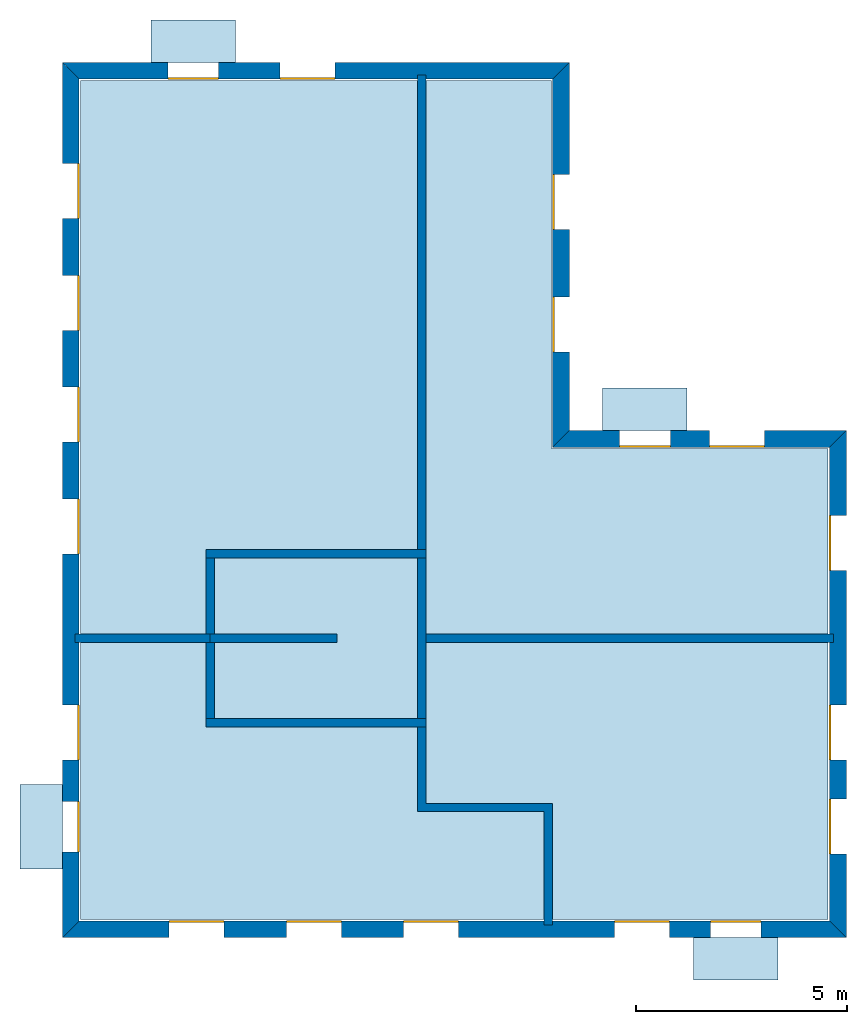
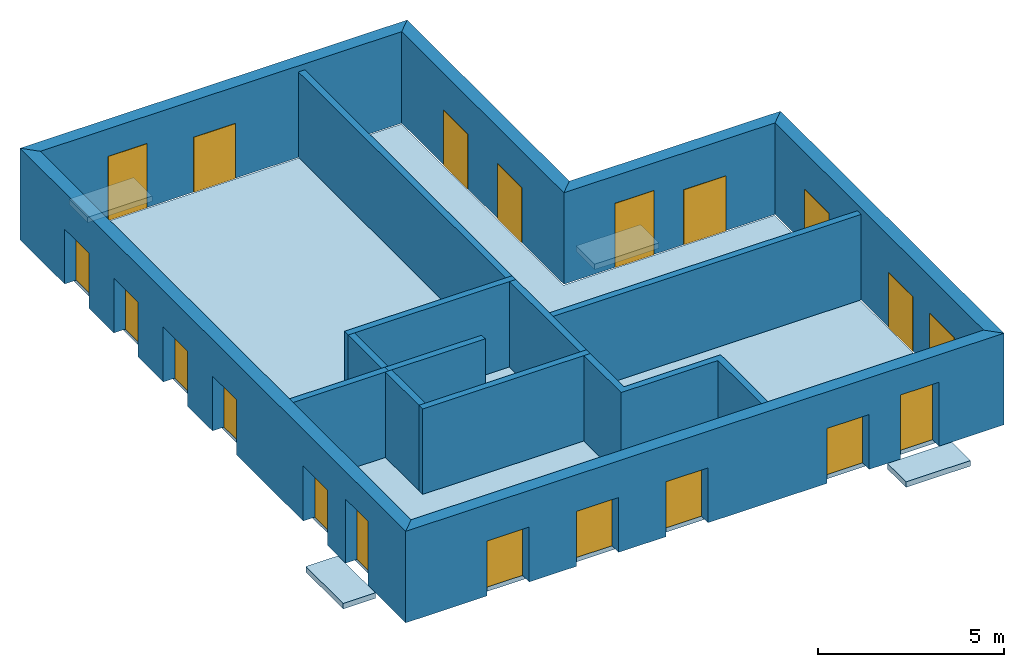
# One storey: 20 windows, 15 walls, 5 slabs, 20 openings.
"""IFC4 building model written with IfcOpenShell, lengths in metres."""

from ifc_helpers import new_model, si_unit, frame, origin_with_axes, place, context, subcontext, project, spatial, line, indexed_curve, outline, extrude, element, fill, save


model = new_model("IFC4")

# Units and contexts
model_context = context("Model", 3, precision=1e-05, world=origin_with_axes())
body_context = subcontext(model_context, "Body", "Model", "MODEL_VIEW")
ifc_project = project(units=[si_unit("VOLUMEUNIT", "CUBIC_METRE"), si_unit("LENGTHUNIT", "METRE"), si_unit("AREAUNIT", "SQUARE_METRE")], contexts=[model_context])

# Site, building, storey
site = spatial("IfcSite", under=ifc_project)
building = spatial("IfcBuilding", under=site, Name="Building 2")
storey_placement = place(None, frame((0.0, 0.0, 4.0), z_axis=(0.0, 0.0, 1.0), x_axis=(1.0, 0.0, 0.0)))
storey = spatial("IfcBuildingStorey", under=building, at=storey_placement, Name="02 Storey")

# Slabs
slab_1_placement = place(storey_placement, origin_with_axes())
element("IfcSlab", 1, at=slab_1_placement, inside=storey, Name="Slab", context=body_context, shape_type="SweptSolid", body=[
    extrude(outline(indexed_curve([(22.109464, -3.589175), (15.563354, -3.589175), (15.563354, 5.1182), (4.423354, 5.1182), (4.423354, -14.729175), (22.109464, -14.729175)], segments=[line(1, 2), line(2, 3), line(3, 4), line(4, 5), line(5, 6)])), origin_with_axes(), (0.0, 0.0, -1.0), 0.2),
])
slab_2_placement = place(storey_placement, origin_with_axes())
element("IfcSlab", 2, at=slab_2_placement, inside=storey, Name="Balcony", context=body_context, shape_type="SweptSolid", body=[
    extrude(outline(indexed_curve([(6.093354, 5.5482), (6.093354, 6.5482), (8.093354, 6.5482), (8.093354, 5.5482)], segments=[line(1, 2), line(2, 3), line(3, 4)])), origin_with_axes(), (0.0, 0.0, -1.0), 0.18),
])
slab_3_placement = place(storey_placement, origin_with_axes())
element("IfcSlab", 3, at=slab_3_placement, inside=storey, Name="Balcony", context=body_context, shape_type="SweptSolid", body=[
    extrude(outline(indexed_curve([(16.7753906666667, -3.159175), (16.7753906666667, -2.159175), (18.7753906666667, -2.159175), (18.7753906666667, -3.159175)], segments=[line(1, 2), line(2, 3), line(3, 4)])), origin_with_axes(), (0.0, 0.0, -1.0), 0.18),
])
slab_4_placement = place(storey_placement, origin_with_axes())
element("IfcSlab", 4, at=slab_4_placement, inside=storey, Name="Balcony", context=body_context, shape_type="SweptSolid", body=[
    extrude(outline(indexed_curve([(20.924094, -15.159175), (20.924094, -16.159175), (18.924094, -16.159175), (18.924094, -15.159175)], segments=[line(1, 2), line(2, 3), line(3, 4)])), origin_with_axes(), (0.0, 0.0, -1.0), 0.18),
])
slab_5_placement = place(storey_placement, origin_with_axes())
element("IfcSlab", 5, at=slab_5_placement, inside=storey, Name="Balcony", context=body_context, shape_type="SweptSolid", body=[
    extrude(outline(indexed_curve([(3.993354, -13.5322976666667), (2.993354, -13.5322976666667), (2.993354, -11.5322976666667), (3.993354, -11.5322976666667)], segments=[line(1, 2), line(2, 3), line(3, 4)])), origin_with_axes(), (0.0, 0.0, -1.0), 0.18),
])

# Walls
wall_1_placement = place(storey_placement, origin_with_axes())
element("IfcWall", 6, at=wall_1_placement, inside=storey, Name="Wall", context=body_context, shape_type="SweptSolid", body=[
    extrude(outline(indexed_curve([(7.593354, -7.978543), (4.293354, -7.978543), (4.293354, -8.178543), (7.593354, -8.178543)], segments=[line(1, 2), line(2, 3), line(3, 4)])), origin_with_axes(), (0.0, 0.0, 1.0), 2.8),
])
wall_2_placement = place(storey_placement, origin_with_axes())
element("IfcWall", 7, at=wall_2_placement, inside=storey, Name="Wall", context=body_context, shape_type="SweptSolid", body=[
    extrude(outline(indexed_curve([(12.593354, 5.2482), (12.393354, 5.2482), (12.393354, -6.178543), (12.593354, -6.178543)], segments=[line(1, 2), line(2, 3), line(3, 4)])), origin_with_axes(), (0.0, 0.0, 1.0), 2.8),
])
wall_3_placement = place(storey_placement, origin_with_axes())
element("IfcWall", 8, at=wall_3_placement, inside=storey, Name="Wall", context=body_context, shape_type="SweptSolid", body=[
    extrude(outline(indexed_curve([(22.239464, -7.978543), (12.393354, -7.978543), (12.393354, -8.178543), (22.239464, -8.178543)], segments=[line(1, 2), line(2, 3), line(3, 4)])), origin_with_axes(), (0.0, 0.0, 1.0), 2.8),
])
wall_4_placement = place(storey_placement, origin_with_axes())
element("IfcWall", 9, at=wall_4_placement, inside=storey, Name="Wall", context=body_context, shape_type="SweptSolid", body=[
    extrude(outline(indexed_curve([(15.593354, -11.978543), (12.593354, -11.978543), (12.593354, -9.978543), (12.393354, -9.978543), (12.393354, -12.178543), (15.393354, -12.178543), (15.393354, -14.859175), (15.593354, -14.859175)], segments=[line(1, 2), line(2, 3), line(3, 4), line(4, 5), line(5, 6), line(6, 7), line(7, 8)])), origin_with_axes(), (0.0, 0.0, 1.0), 2.8),
])

# Wall, openings, windows
wall_5_placement = place(storey_placement, origin_with_axes())
wall_5 = element("IfcWall", 10, at=wall_5_placement, inside=storey, Name="Facade", context=body_context, shape_type="SweptSolid", body=[
    extrude(outline(indexed_curve([(22.139464, -3.559175), (15.593354, -3.559175), (15.993354, -3.159175), (22.539464, -3.159175)], segments=[line(1, 2), line(2, 3), line(3, 4)])), origin_with_axes(), (0.0, 0.0, 1.0), 3.0),
])
opening_1_placement = place(wall_5_placement, origin_with_axes())
opening_1 = element("IfcOpeningElement", 11, at=opening_1_placement, cuts=wall_5, Name="Opening", context=body_context, shape_type="SweptSolid", body=[
    extrude(outline(indexed_curve([(20.6074273333333, -3.119175), (20.6074273333333, -3.619175), (19.3074273333333, -3.619175), (19.3074273333333, -3.119175)], segments=[line(1, 2), line(2, 3), line(3, 4)])), origin_with_axes(), (0.0, 0.0, 1.0), 1.8),
])
opening_2_placement = place(wall_5_placement, origin_with_axes())
opening_2 = element("IfcOpeningElement", 12, at=opening_2_placement, cuts=wall_5, Name="Opening", context=body_context, shape_type="SweptSolid", body=[
    extrude(outline(indexed_curve([(18.3753906666667, -3.119175), (18.3753906666667, -3.619175), (17.1753906666667, -3.619175), (17.1753906666667, -3.119175)], segments=[line(1, 2), line(2, 3), line(3, 4)])), origin_with_axes(), (0.0, 0.0, 1.0), 2.1),
])
window_1_placement = place(storey_placement, origin_with_axes())
window_1 = element("IfcWindow", 13, at=window_1_placement, inside=storey, Name="Window", PredefinedType="WINDOW", context=body_context, shape_type="SweptSolid", body=[
    extrude(outline(indexed_curve([(20.6074273333333, -3.519175), (20.6074273333333, -3.569175), (19.3074273333333, -3.569175), (19.3074273333333, -3.519175)], segments=[line(1, 2), line(2, 3), line(3, 4)])), origin_with_axes(), (0.0, 0.0, 1.0), 1.8),
])
fill(opening_1, window_1)
window_2_placement = place(storey_placement, origin_with_axes())
window_2 = element("IfcWindow", 14, at=window_2_placement, inside=storey, Name="Window", PredefinedType="WINDOW", context=body_context, shape_type="SweptSolid", body=[
    extrude(outline(indexed_curve([(18.3753906666667, -3.519175), (18.3753906666667, -3.569175), (17.1753906666667, -3.569175), (17.1753906666667, -3.519175)], segments=[line(1, 2), line(2, 3), line(3, 4)])), origin_with_axes(), (0.0, 0.0, 1.0), 2.1),
])
fill(opening_2, window_2)

wall_6_placement = place(storey_placement, origin_with_axes())
wall_6 = element("IfcWall", 15, at=wall_6_placement, inside=storey, Name="Facade", context=body_context, shape_type="SweptSolid", body=[
    extrude(outline(indexed_curve([(15.593354, -3.559175), (15.593354, 5.1482), (15.993354, 5.5482), (15.993354, -3.159175)], segments=[line(1, 2), line(2, 3), line(3, 4)])), origin_with_axes(), (0.0, 0.0, 1.0), 3.0),
])
opening_3_placement = place(wall_6_placement, origin_with_axes())
opening_3 = element("IfcOpeningElement", 16, at=opening_3_placement, cuts=wall_6, Name="Opening", context=body_context, shape_type="SweptSolid", body=[
    extrude(outline(indexed_curve([(16.033354, -1.30671666666667), (15.533354, -1.30671666666667), (15.533354, -0.00671666666666659), (16.033354, -0.00671666666666659)], segments=[line(1, 2), line(2, 3), line(3, 4)])), origin_with_axes(), (0.0, 0.0, 1.0), 1.8),
])
opening_4_placement = place(wall_6_placement, origin_with_axes())
opening_4 = element("IfcOpeningElement", 17, at=opening_4_placement, cuts=wall_6, Name="Opening", context=body_context, shape_type="SweptSolid", body=[
    extrude(outline(indexed_curve([(16.033354, 1.59574166666667), (15.533354, 1.59574166666667), (15.533354, 2.89574166666667), (16.033354, 2.89574166666667)], segments=[line(1, 2), line(2, 3), line(3, 4)])), origin_with_axes(), (0.0, 0.0, 1.0), 1.8),
])
window_3_placement = place(storey_placement, origin_with_axes())
window_3 = element("IfcWindow", 18, at=window_3_placement, inside=storey, Name="Window", PredefinedType="WINDOW", context=body_context, shape_type="SweptSolid", body=[
    extrude(outline(indexed_curve([(15.633354, -1.30671666666667), (15.583354, -1.30671666666667), (15.583354, -0.00671666666666659), (15.633354, -0.00671666666666659)], segments=[line(1, 2), line(2, 3), line(3, 4)])), origin_with_axes(), (0.0, 0.0, 1.0), 1.8),
])
fill(opening_3, window_3)
window_4_placement = place(storey_placement, origin_with_axes())
window_4 = element("IfcWindow", 19, at=window_4_placement, inside=storey, Name="Window", PredefinedType="WINDOW", context=body_context, shape_type="SweptSolid", body=[
    extrude(outline(indexed_curve([(15.633354, 1.59574166666667), (15.583354, 1.59574166666667), (15.583354, 2.89574166666667), (15.633354, 2.89574166666667)], segments=[line(1, 2), line(2, 3), line(3, 4)])), origin_with_axes(), (0.0, 0.0, 1.0), 1.8),
])
fill(opening_4, window_4)

wall_7_placement = place(storey_placement, origin_with_axes())
wall_7 = element("IfcWall", 20, at=wall_7_placement, inside=storey, Name="Facade", context=body_context, shape_type="SweptSolid", body=[
    extrude(outline(indexed_curve([(15.593354, 5.1482), (4.393354, 5.1482), (3.993354, 5.5482), (15.993354, 5.5482)], segments=[line(1, 2), line(2, 3), line(3, 4)])), origin_with_axes(), (0.0, 0.0, 1.0), 3.0),
])
opening_5_placement = place(wall_7_placement, origin_with_axes())
opening_5 = element("IfcOpeningElement", 21, at=opening_5_placement, cuts=wall_7, Name="Opening", context=body_context, shape_type="SweptSolid", body=[
    extrude(outline(indexed_curve([(10.443354, 5.5882), (10.443354, 5.0882), (9.143354, 5.0882), (9.143354, 5.5882)], segments=[line(1, 2), line(2, 3), line(3, 4)])), origin_with_axes(), (0.0, 0.0, 1.0), 1.8),
])
opening_6_placement = place(wall_7_placement, origin_with_axes())
opening_6 = element("IfcOpeningElement", 22, at=opening_6_placement, cuts=wall_7, Name="Opening", context=body_context, shape_type="SweptSolid", body=[
    extrude(outline(indexed_curve([(7.693354, 5.5882), (7.693354, 5.0882), (6.493354, 5.0882), (6.493354, 5.5882)], segments=[line(1, 2), line(2, 3), line(3, 4)])), origin_with_axes(), (0.0, 0.0, 1.0), 2.1),
])
window_5_placement = place(storey_placement, origin_with_axes())
window_5 = element("IfcWindow", 23, at=window_5_placement, inside=storey, Name="Window", PredefinedType="WINDOW", context=body_context, shape_type="SweptSolid", body=[
    extrude(outline(indexed_curve([(10.443354, 5.1882), (10.443354, 5.1382), (9.143354, 5.1382), (9.143354, 5.1882)], segments=[line(1, 2), line(2, 3), line(3, 4)])), origin_with_axes(), (0.0, 0.0, 1.0), 1.8),
])
fill(opening_5, window_5)
window_6_placement = place(storey_placement, origin_with_axes())
window_6 = element("IfcWindow", 24, at=window_6_placement, inside=storey, Name="Window", PredefinedType="WINDOW", context=body_context, shape_type="SweptSolid", body=[
    extrude(outline(indexed_curve([(7.693354, 5.1882), (7.693354, 5.1382), (6.493354, 5.1382), (6.493354, 5.1882)], segments=[line(1, 2), line(2, 3), line(3, 4)])), origin_with_axes(), (0.0, 0.0, 1.0), 2.1),
])
fill(opening_6, window_6)

wall_8_placement = place(storey_placement, origin_with_axes())
wall_8 = element("IfcWall", 25, at=wall_8_placement, inside=storey, Name="Facade", context=body_context, shape_type="SweptSolid", body=[
    extrude(outline(indexed_curve([(4.393354, 5.1482), (4.393354, -14.759175), (3.993354, -15.159175), (3.993354, 5.5482)], segments=[line(1, 2), line(2, 3), line(3, 4)])), origin_with_axes(), (0.0, 0.0, 1.0), 3.0),
])
opening_7_placement = place(wall_8_placement, origin_with_axes())
opening_7 = element("IfcOpeningElement", 26, at=opening_7_placement, cuts=wall_8, Name="Opening", context=body_context, shape_type="SweptSolid", body=[
    extrude(outline(indexed_curve([(3.953354, 3.1528514), (4.453354, 3.1528514), (4.453354, 1.8528514), (3.953354, 1.8528514)], segments=[line(1, 2), line(2, 3), line(3, 4)])), origin_with_axes(), (0.0, 0.0, 1.0), 1.8),
])
opening_8_placement = place(wall_8_placement, origin_with_axes())
opening_8 = element("IfcOpeningElement", 27, at=opening_8_placement, cuts=wall_8, Name="Opening", context=body_context, shape_type="SweptSolid", body=[
    extrude(outline(indexed_curve([(3.953354, 0.507502800000001), (4.453354, 0.507502800000001), (4.453354, -0.792497199999999), (3.953354, -0.792497199999999)], segments=[line(1, 2), line(2, 3), line(3, 4)])), origin_with_axes(), (0.0, 0.0, 1.0), 1.8),
])
opening_9_placement = place(wall_8_placement, origin_with_axes())
opening_9 = element("IfcOpeningElement", 28, at=opening_9_placement, cuts=wall_8, Name="Opening", context=body_context, shape_type="SweptSolid", body=[
    extrude(outline(indexed_curve([(3.953354, -2.1378458), (4.453354, -2.1378458), (4.453354, -3.4378458), (3.953354, -3.4378458)], segments=[line(1, 2), line(2, 3), line(3, 4)])), origin_with_axes(), (0.0, 0.0, 1.0), 1.8),
])
opening_10_placement = place(wall_8_placement, origin_with_axes())
opening_10 = element("IfcOpeningElement", 29, at=opening_10_placement, cuts=wall_8, Name="Opening", context=body_context, shape_type="SweptSolid", body=[
    extrude(outline(indexed_curve([(3.953354, -4.7831944), (4.453354, -4.7831944), (4.453354, -6.0831944), (3.953354, -6.0831944)], segments=[line(1, 2), line(2, 3), line(3, 4)])), origin_with_axes(), (0.0, 0.0, 1.0), 1.8),
])
opening_11_placement = place(wall_8_placement, origin_with_axes())
opening_11 = element("IfcOpeningElement", 30, at=opening_11_placement, cuts=wall_8, Name="Opening", context=body_context, shape_type="SweptSolid", body=[
    extrude(outline(indexed_curve([(3.953354, -9.65542033333333), (4.453354, -9.65542033333333), (4.453354, -10.9554203333333), (3.953354, -10.9554203333333)], segments=[line(1, 2), line(2, 3), line(3, 4)])), origin_with_axes(), (0.0, 0.0, 1.0), 1.8),
])
opening_12_placement = place(wall_8_placement, origin_with_axes())
opening_12 = element("IfcOpeningElement", 31, at=opening_12_placement, cuts=wall_8, Name="Opening", context=body_context, shape_type="SweptSolid", body=[
    extrude(outline(indexed_curve([(3.953354, -11.9322976666667), (4.453354, -11.9322976666667), (4.453354, -13.1322976666667), (3.953354, -13.1322976666667)], segments=[line(1, 2), line(2, 3), line(3, 4)])), origin_with_axes(), (0.0, 0.0, 1.0), 2.1),
])
window_7_placement = place(storey_placement, origin_with_axes())
window_7 = element("IfcWindow", 32, at=window_7_placement, inside=storey, Name="Window", PredefinedType="WINDOW", context=body_context, shape_type="SweptSolid", body=[
    extrude(outline(indexed_curve([(4.353354, 3.1528514), (4.403354, 3.1528514), (4.403354, 1.8528514), (4.353354, 1.8528514)], segments=[line(1, 2), line(2, 3), line(3, 4)])), origin_with_axes(), (0.0, 0.0, 1.0), 1.8),
])
fill(opening_7, window_7)
window_8_placement = place(storey_placement, origin_with_axes())
window_8 = element("IfcWindow", 33, at=window_8_placement, inside=storey, Name="Window", PredefinedType="WINDOW", context=body_context, shape_type="SweptSolid", body=[
    extrude(outline(indexed_curve([(4.353354, 0.507502800000001), (4.403354, 0.507502800000001), (4.403354, -0.792497199999999), (4.353354, -0.792497199999999)], segments=[line(1, 2), line(2, 3), line(3, 4)])), origin_with_axes(), (0.0, 0.0, 1.0), 1.8),
])
fill(opening_8, window_8)
window_9_placement = place(storey_placement, origin_with_axes())
window_9 = element("IfcWindow", 34, at=window_9_placement, inside=storey, Name="Window", PredefinedType="WINDOW", context=body_context, shape_type="SweptSolid", body=[
    extrude(outline(indexed_curve([(4.353354, -2.1378458), (4.403354, -2.1378458), (4.403354, -3.4378458), (4.353354, -3.4378458)], segments=[line(1, 2), line(2, 3), line(3, 4)])), origin_with_axes(), (0.0, 0.0, 1.0), 1.8),
])
fill(opening_9, window_9)
window_10_placement = place(storey_placement, origin_with_axes())
window_10 = element("IfcWindow", 35, at=window_10_placement, inside=storey, Name="Window", PredefinedType="WINDOW", context=body_context, shape_type="SweptSolid", body=[
    extrude(outline(indexed_curve([(4.353354, -4.7831944), (4.403354, -4.7831944), (4.403354, -6.0831944), (4.353354, -6.0831944)], segments=[line(1, 2), line(2, 3), line(3, 4)])), origin_with_axes(), (0.0, 0.0, 1.0), 1.8),
])
fill(opening_10, window_10)
window_11_placement = place(storey_placement, origin_with_axes())
window_11 = element("IfcWindow", 36, at=window_11_placement, inside=storey, Name="Window", PredefinedType="WINDOW", context=body_context, shape_type="SweptSolid", body=[
    extrude(outline(indexed_curve([(4.353354, -9.65542033333333), (4.403354, -9.65542033333333), (4.403354, -10.9554203333333), (4.353354, -10.9554203333333)], segments=[line(1, 2), line(2, 3), line(3, 4)])), origin_with_axes(), (0.0, 0.0, 1.0), 1.8),
])
fill(opening_11, window_11)
window_12_placement = place(storey_placement, origin_with_axes())
window_12 = element("IfcWindow", 37, at=window_12_placement, inside=storey, Name="Window", PredefinedType="WINDOW", context=body_context, shape_type="SweptSolid", body=[
    extrude(outline(indexed_curve([(4.353354, -11.9322976666667), (4.403354, -11.9322976666667), (4.403354, -13.1322976666667), (4.353354, -13.1322976666667)], segments=[line(1, 2), line(2, 3), line(3, 4)])), origin_with_axes(), (0.0, 0.0, 1.0), 2.1),
])
fill(opening_12, window_12)

wall_9_placement = place(storey_placement, origin_with_axes())
wall_9 = element("IfcWall", 38, at=wall_9_placement, inside=storey, Name="Facade", context=body_context, shape_type="SweptSolid", body=[
    extrude(outline(indexed_curve([(4.393354, -14.759175), (22.139464, -14.759175), (22.539464, -15.159175), (3.993354, -15.159175)], segments=[line(1, 2), line(2, 3), line(3, 4)])), origin_with_axes(), (0.0, 0.0, 1.0), 3.0),
])
opening_13_placement = place(wall_9_placement, origin_with_axes())
opening_13 = element("IfcOpeningElement", 39, at=opening_13_placement, cuts=wall_9, Name="Opening", context=body_context, shape_type="SweptSolid", body=[
    extrude(outline(indexed_curve([(17.058724, -15.199175), (17.058724, -14.699175), (18.358724, -14.699175), (18.358724, -15.199175)], segments=[line(1, 2), line(2, 3), line(3, 4)])), origin_with_axes(), (0.0, 0.0, 1.0), 1.8),
])
opening_14_placement = place(wall_9_placement, origin_with_axes())
opening_14 = element("IfcOpeningElement", 40, at=opening_14_placement, cuts=wall_9, Name="Opening", context=body_context, shape_type="SweptSolid", body=[
    extrude(outline(indexed_curve([(19.324094, -15.199175), (19.324094, -14.699175), (20.524094, -14.699175), (20.524094, -15.199175)], segments=[line(1, 2), line(2, 3), line(3, 4)])), origin_with_axes(), (0.0, 0.0, 1.0), 2.1),
])
opening_15_placement = place(wall_9_placement, origin_with_axes())
opening_15 = element("IfcOpeningElement", 41, at=opening_15_placement, cuts=wall_9, Name="Opening", context=body_context, shape_type="SweptSolid", body=[
    extrude(outline(indexed_curve([(6.518354, -15.199175), (6.518354, -14.699175), (7.818354, -14.699175), (7.818354, -15.199175)], segments=[line(1, 2), line(2, 3), line(3, 4)])), origin_with_axes(), (0.0, 0.0, 1.0), 1.8),
])
opening_16_placement = place(wall_9_placement, origin_with_axes())
opening_16 = element("IfcOpeningElement", 42, at=opening_16_placement, cuts=wall_9, Name="Opening", context=body_context, shape_type="SweptSolid", body=[
    extrude(outline(indexed_curve([(9.293354, -15.199175), (9.293354, -14.699175), (10.593354, -14.699175), (10.593354, -15.199175)], segments=[line(1, 2), line(2, 3), line(3, 4)])), origin_with_axes(), (0.0, 0.0, 1.0), 1.8),
])
opening_17_placement = place(wall_9_placement, origin_with_axes())
opening_17 = element("IfcOpeningElement", 43, at=opening_17_placement, cuts=wall_9, Name="Opening", context=body_context, shape_type="SweptSolid", body=[
    extrude(outline(indexed_curve([(12.068354, -15.199175), (12.068354, -14.699175), (13.368354, -14.699175), (13.368354, -15.199175)], segments=[line(1, 2), line(2, 3), line(3, 4)])), origin_with_axes(), (0.0, 0.0, 1.0), 1.8),
])
window_13_placement = place(storey_placement, origin_with_axes())
window_13 = element("IfcWindow", 44, at=window_13_placement, inside=storey, Name="Window", PredefinedType="WINDOW", context=body_context, shape_type="SweptSolid", body=[
    extrude(outline(indexed_curve([(17.058724, -14.799175), (17.058724, -14.749175), (18.358724, -14.749175), (18.358724, -14.799175)], segments=[line(1, 2), line(2, 3), line(3, 4)])), origin_with_axes(), (0.0, 0.0, 1.0), 1.8),
])
fill(opening_13, window_13)
window_14_placement = place(storey_placement, origin_with_axes())
window_14 = element("IfcWindow", 45, at=window_14_placement, inside=storey, Name="Window", PredefinedType="WINDOW", context=body_context, shape_type="SweptSolid", body=[
    extrude(outline(indexed_curve([(19.324094, -14.799175), (19.324094, -14.749175), (20.524094, -14.749175), (20.524094, -14.799175)], segments=[line(1, 2), line(2, 3), line(3, 4)])), origin_with_axes(), (0.0, 0.0, 1.0), 2.1),
])
fill(opening_14, window_14)
window_15_placement = place(storey_placement, origin_with_axes())
window_15 = element("IfcWindow", 46, at=window_15_placement, inside=storey, Name="Window", PredefinedType="WINDOW", context=body_context, shape_type="SweptSolid", body=[
    extrude(outline(indexed_curve([(6.518354, -14.799175), (6.518354, -14.749175), (7.818354, -14.749175), (7.818354, -14.799175)], segments=[line(1, 2), line(2, 3), line(3, 4)])), origin_with_axes(), (0.0, 0.0, 1.0), 1.8),
])
fill(opening_15, window_15)
window_16_placement = place(storey_placement, origin_with_axes())
window_16 = element("IfcWindow", 47, at=window_16_placement, inside=storey, Name="Window", PredefinedType="WINDOW", context=body_context, shape_type="SweptSolid", body=[
    extrude(outline(indexed_curve([(9.293354, -14.799175), (9.293354, -14.749175), (10.593354, -14.749175), (10.593354, -14.799175)], segments=[line(1, 2), line(2, 3), line(3, 4)])), origin_with_axes(), (0.0, 0.0, 1.0), 1.8),
])
fill(opening_16, window_16)
window_17_placement = place(storey_placement, origin_with_axes())
window_17 = element("IfcWindow", 48, at=window_17_placement, inside=storey, Name="Window", PredefinedType="WINDOW", context=body_context, shape_type="SweptSolid", body=[
    extrude(outline(indexed_curve([(12.068354, -14.799175), (12.068354, -14.749175), (13.368354, -14.749175), (13.368354, -14.799175)], segments=[line(1, 2), line(2, 3), line(3, 4)])), origin_with_axes(), (0.0, 0.0, 1.0), 1.8),
])
fill(opening_17, window_17)

wall_10_placement = place(storey_placement, origin_with_axes())
wall_10 = element("IfcWall", 49, at=wall_10_placement, inside=storey, Name="Facade", context=body_context, shape_type="SweptSolid", body=[
    extrude(outline(indexed_curve([(22.139464, -14.759175), (22.139464, -3.559175), (22.539464, -3.159175), (22.539464, -15.159175)], segments=[line(1, 2), line(2, 3), line(3, 4)])), origin_with_axes(), (0.0, 0.0, 1.0), 3.0),
])
opening_18_placement = place(wall_10_placement, origin_with_axes())
opening_18 = element("IfcOpeningElement", 50, at=opening_18_placement, cuts=wall_10, Name="Opening", context=body_context, shape_type="SweptSolid", body=[
    extrude(outline(indexed_curve([(22.579464, -6.468859), (22.079464, -6.468859), (22.079464, -5.168859), (22.579464, -5.168859)], segments=[line(1, 2), line(2, 3), line(3, 4)])), origin_with_axes(), (0.0, 0.0, 1.0), 1.8),
])
opening_19_placement = place(wall_10_placement, origin_with_axes())
opening_19 = element("IfcOpeningElement", 51, at=opening_19_placement, cuts=wall_10, Name="Opening", context=body_context, shape_type="SweptSolid", body=[
    extrude(outline(indexed_curve([(22.579464, -13.1822976666667), (22.079464, -13.1822976666667), (22.079464, -11.8822976666667), (22.579464, -11.8822976666667)], segments=[line(1, 2), line(2, 3), line(3, 4)])), origin_with_axes(), (0.0, 0.0, 1.0), 1.8),
])
opening_20_placement = place(wall_10_placement, origin_with_axes())
opening_20 = element("IfcOpeningElement", 52, at=opening_20_placement, cuts=wall_10, Name="Opening", context=body_context, shape_type="SweptSolid", body=[
    extrude(outline(indexed_curve([(22.579464, -10.9554203333333), (22.079464, -10.9554203333333), (22.079464, -9.65542033333333), (22.579464, -9.65542033333333)], segments=[line(1, 2), line(2, 3), line(3, 4)])), origin_with_axes(), (0.0, 0.0, 1.0), 1.8),
])
window_18_placement = place(storey_placement, origin_with_axes())
window_18 = element("IfcWindow", 53, at=window_18_placement, inside=storey, Name="Window", PredefinedType="WINDOW", context=body_context, shape_type="SweptSolid", body=[
    extrude(outline(indexed_curve([(22.179464, -6.468859), (22.129464, -6.468859), (22.129464, -5.168859), (22.179464, -5.168859)], segments=[line(1, 2), line(2, 3), line(3, 4)])), origin_with_axes(), (0.0, 0.0, 1.0), 1.8),
])
fill(opening_18, window_18)
window_19_placement = place(storey_placement, origin_with_axes())
window_19 = element("IfcWindow", 54, at=window_19_placement, inside=storey, Name="Window", PredefinedType="WINDOW", context=body_context, shape_type="SweptSolid", body=[
    extrude(outline(indexed_curve([(22.179464, -13.1822976666667), (22.129464, -13.1822976666667), (22.129464, -11.8822976666667), (22.179464, -11.8822976666667)], segments=[line(1, 2), line(2, 3), line(3, 4)])), origin_with_axes(), (0.0, 0.0, 1.0), 1.8),
])
fill(opening_19, window_19)
window_20_placement = place(storey_placement, origin_with_axes())
window_20 = element("IfcWindow", 55, at=window_20_placement, inside=storey, Name="Window", PredefinedType="WINDOW", context=body_context, shape_type="SweptSolid", body=[
    extrude(outline(indexed_curve([(22.179464, -10.9554203333333), (22.129464, -10.9554203333333), (22.129464, -9.65542033333333), (22.179464, -9.65542033333333)], segments=[line(1, 2), line(2, 3), line(3, 4)])), origin_with_axes(), (0.0, 0.0, 1.0), 1.8),
])
fill(opening_20, window_20)

# Walls
wall_11_placement = place(storey_placement, origin_with_axes())
element("IfcWall", 56, at=wall_11_placement, inside=storey, Name="CoreWall", context=body_context, shape_type="SweptSolid", body=[
    extrude(outline(indexed_curve([(12.593354, -5.978543), (7.393354, -5.978543), (7.393354, -6.178543), (12.593354, -6.178543)], segments=[line(1, 2), line(2, 3), line(3, 4)])), origin_with_axes(), (0.0, 0.0, 1.0), 2.8),
])
wall_12_placement = place(storey_placement, origin_with_axes())
element("IfcWall", 57, at=wall_12_placement, inside=storey, Name="CoreWall", context=body_context, shape_type="SweptSolid", body=[
    extrude(outline(indexed_curve([(7.393354, -10.178543), (12.593354, -10.178543), (12.593354, -9.978543), (7.393354, -9.978543)], segments=[line(1, 2), line(2, 3), line(3, 4)])), origin_with_axes(), (0.0, 0.0, 1.0), 2.8),
])
wall_13_placement = place(storey_placement, origin_with_axes())
element("IfcWall", 58, at=wall_13_placement, inside=storey, Name="CoreWall", context=body_context, shape_type="SweptSolid", body=[
    extrude(outline(indexed_curve([(7.593354, -9.978543), (7.593354, -6.178543), (7.393354, -6.178543), (7.393354, -9.978543)], segments=[line(1, 2), line(2, 3), line(3, 4)])), origin_with_axes(), (0.0, 0.0, 1.0), 2.8),
])
wall_14_placement = place(storey_placement, origin_with_axes())
element("IfcWall", 59, at=wall_14_placement, inside=storey, Name="CoreWall", context=body_context, shape_type="SweptSolid", body=[
    extrude(outline(indexed_curve([(12.393354, -6.178543), (12.393354, -9.978543), (12.593354, -9.978543), (12.593354, -6.178543)], segments=[line(1, 2), line(2, 3), line(3, 4)])), origin_with_axes(), (0.0, 0.0, 1.0), 2.8),
])
wall_15_placement = place(storey_placement, origin_with_axes())
element("IfcWall", 60, at=wall_15_placement, inside=storey, Name="CoreWall", context=body_context, shape_type="SweptSolid", body=[
    extrude(outline(indexed_curve([(10.493354, -7.978543), (7.493354, -7.978543), (7.493354, -8.178543), (10.493354, -8.178543)], segments=[line(1, 2), line(2, 3), line(3, 4)])), origin_with_axes(), (0.0, 0.0, 1.0), 2.8),
])

save(model, "model.ifc")
